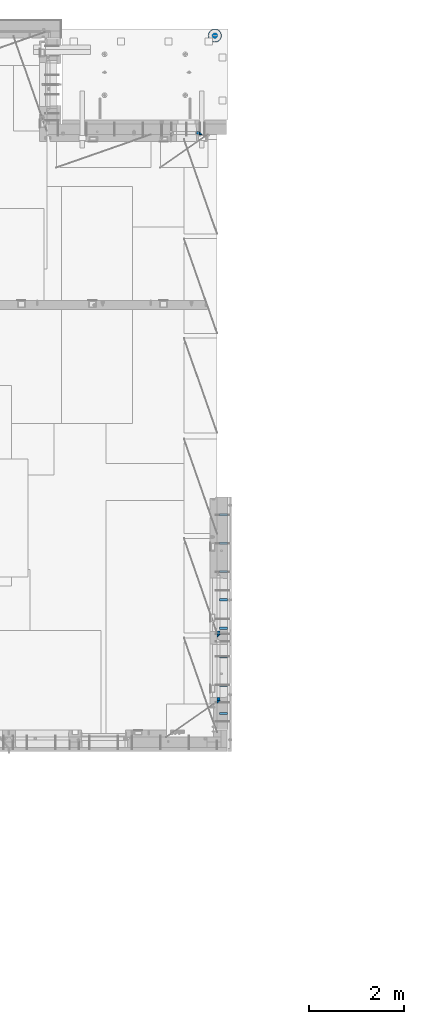
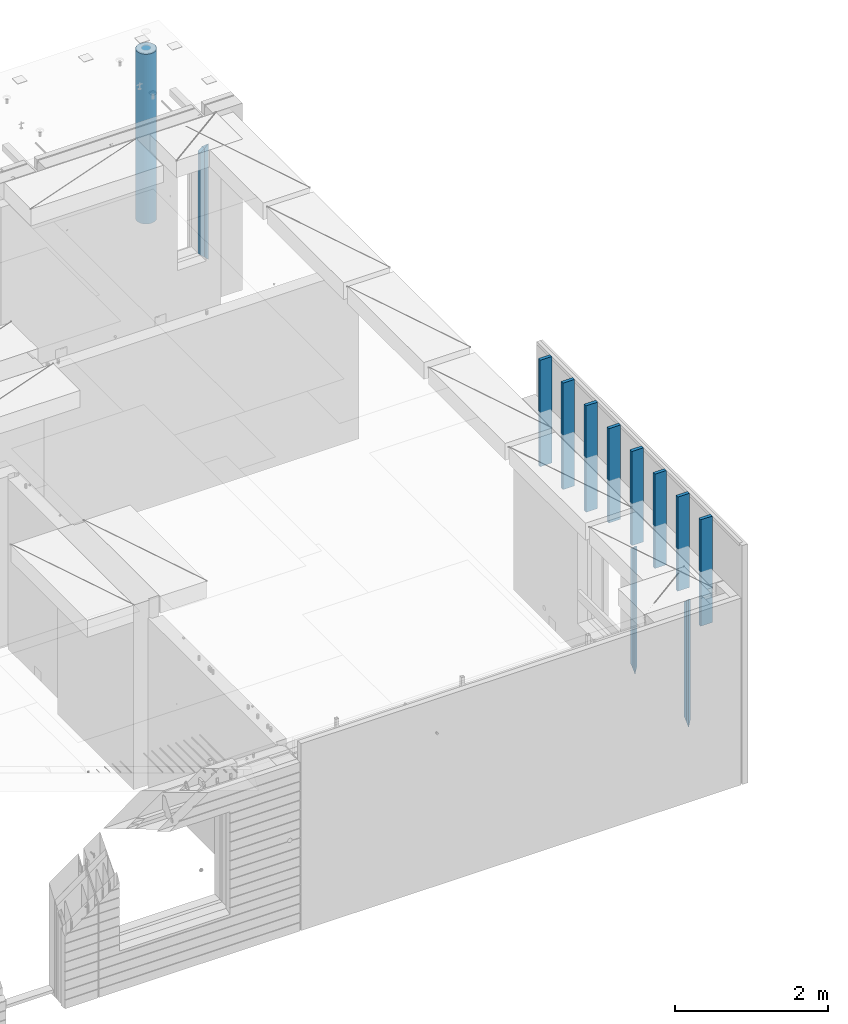
# One storey, part 6 of 309: 15 columns, 3 elements without a shape of their own.
"""IFC2X3 building model written with IfcOpenShell, lengths in millimetres."""

from ifc_helpers import new_model, si_unit, frame, origin_with_axes, place, context, subcontext, project, spatial, faceted_brep, material, type_object, element, aggregate, save


model = new_model("IFC2X3")

# Units and contexts
model_context = context("Model", 3, precision=1e-05, world=origin_with_axes())
body_context = subcontext(model_context, "Body", "Model", "MODEL_VIEW")
ifc_project = project(units=[si_unit("LENGTHUNIT", "METRE", prefix="MILLI"), si_unit("AREAUNIT", "SQUARE_METRE"), si_unit("VOLUMEUNIT", "CUBIC_METRE"), si_unit("MASSUNIT", "GRAM", prefix="KILO"), si_unit("TIMEUNIT", "SECOND"), si_unit("PLANEANGLEUNIT", "RADIAN"), si_unit("SOLIDANGLEUNIT", "STERADIAN"), si_unit("THERMODYNAMICTEMPERATUREUNIT", "DEGREE_CELSIUS"), si_unit("LUMINOUSINTENSITYUNIT", "LUMEN")], contexts=[model_context])

# Site, building, storey
site_placement = place(None, origin_with_axes())
site = spatial("IfcSite", under=ifc_project, at=site_placement, CompositionType="ELEMENT")
building_placement = place(site_placement, origin_with_axes())
building = spatial("IfcBuilding", under=site, at=building_placement, CompositionType="ELEMENT")
storey_placement = place(building_placement, origin_with_axes())
storey = spatial("IfcBuildingStorey", under=building, at=storey_placement, Name="7", CompositionType="ELEMENT", Elevation=0.0)

# Assembly, columns
assembly_1_placement = place(storey_placement, origin_with_axes())
assembly_1 = element("IfcElementAssembly", 1, at=assembly_1_placement, inside=storey, AssemblyPlace="NOTDEFINED", PredefinedType="REINFORCEMENT_UNIT")
ifc_material_1 = material(Name="TIMBER/T24")
column_type_1 = type_object("IfcColumnType", Name="PK50X175", PredefinedType="NOTDEFINED")
column_1_placement = place(assembly_1_placement, frame((35192.5, 8350.00024414063, 101870.0), z_axis=(-1.0, 3.00000001838171e-08, 0.0), x_axis=(0.0, 0.0, 1.0)))
column_1 = element("IfcColumn", 2, at=column_1_placement, type_object=column_type_1, material=ifc_material_1, ObjectType="PK50X175", context=body_context, shape_type="Brep", body=[
    faceted_brep([(0.0, 25.0, 87.5), (0.0, -25.0, 87.5), (1700.0, -25.0, 87.5), (1700.0, 25.0, 87.5), (0.0, -25.0, -87.5), (1700.0, -25.0, -87.5), (0.0, 25.0, -87.5), (1700.0, 25.0, -87.5)], [[[0, 1, 2, 3]], [[1, 4, 5, 2]], [[4, 6, 7, 5]], [[6, 0, 3, 7]], [[5, 7, 3, 2]], [[6, 4, 1, 0]]]),
])
column_2_placement = place(assembly_1_placement, frame((35192.5, 8950.00024414063, 102065.0), z_axis=(-1.0, 3.00000001838171e-08, 0.0), x_axis=(0.0, 0.0, 1.0)))
column_2 = element("IfcColumn", 3, at=column_2_placement, type_object=column_type_1, material=ifc_material_1, ObjectType="PK50X175", context=body_context, shape_type="Brep", body=[
    faceted_brep([(0.0, 25.0, 87.5), (0.0, -25.0, 87.5), (1505.0, -25.0, 87.5), (1505.0, 25.0, 87.5), (0.0, -25.0, -87.5), (1505.0, -25.0, -87.5), (0.0, 25.0, -87.5), (1505.0, 25.0, -87.5)], [[[0, 1, 2, 3]], [[1, 4, 5, 2]], [[4, 6, 7, 5]], [[6, 0, 3, 7]], [[5, 7, 3, 2]], [[6, 4, 1, 0]]]),
])
column_3_placement = place(assembly_1_placement, frame((35192.5, 9550.00024414063, 102065.0), z_axis=(-1.0, 3.00000001838171e-08, 0.0), x_axis=(0.0, 0.0, 1.0)))
column_3 = element("IfcColumn", 4, at=column_3_placement, type_object=column_type_1, material=ifc_material_1, ObjectType="PK50X175", context=body_context, shape_type="Brep", body=[
    faceted_brep([(0.0, 25.0, 87.5), (0.0, -25.0, 87.5), (1505.0, -25.0, 87.5), (1505.0, 25.0, 87.5), (0.0, -25.0, -87.5), (1505.0, -25.0, -87.5), (0.0, 25.0, -87.5), (1505.0, 25.0, -87.5)], [[[0, 1, 2, 3]], [[1, 4, 5, 2]], [[4, 6, 7, 5]], [[6, 0, 3, 7]], [[5, 7, 3, 2]], [[6, 4, 1, 0]]]),
])
column_4_placement = place(assembly_1_placement, frame((35192.5, 10150.0002441406, 102065.0), z_axis=(-1.0, 3.00000001838171e-08, 0.0), x_axis=(0.0, 0.0, 1.0)))
column_4 = element("IfcColumn", 5, at=column_4_placement, type_object=column_type_1, material=ifc_material_1, ObjectType="PK50X175", context=body_context, shape_type="Brep", body=[
    faceted_brep([(0.0, 25.0, 87.5), (0.0, -25.0, 87.5), (1505.0, -25.0, 87.5), (1505.0, 25.0, 87.5), (0.0, -25.0, -87.5), (1505.0, -25.0, -87.5), (0.0, 25.0, -87.5), (1505.0, 25.0, -87.5)], [[[0, 1, 2, 3]], [[1, 4, 5, 2]], [[4, 6, 7, 5]], [[6, 0, 3, 7]], [[5, 7, 3, 2]], [[6, 4, 1, 0]]]),
])
column_5_placement = place(assembly_1_placement, frame((35192.5, 10750.0002441406, 102065.0), z_axis=(-1.0, 3.00000001838171e-08, 0.0), x_axis=(0.0, 0.0, 1.0)))
column_5 = element("IfcColumn", 6, at=column_5_placement, type_object=column_type_1, material=ifc_material_1, ObjectType="PK50X175", context=body_context, shape_type="Brep", body=[
    faceted_brep([(0.0, 25.0, 87.5), (0.0, -25.0, 87.5), (1505.0, -25.0, 87.5), (1505.0, 25.0, 87.5), (0.0, -25.0, -87.5), (1505.0, -25.0, -87.5), (0.0, 25.0, -87.5), (1505.0, 25.0, -87.5)], [[[0, 1, 2, 3]], [[1, 4, 5, 2]], [[4, 6, 7, 5]], [[6, 0, 3, 7]], [[5, 7, 3, 2]], [[6, 4, 1, 0]]]),
])
column_6_placement = place(assembly_1_placement, frame((35192.5, 11350.0002441406, 101870.0), z_axis=(-1.0, 3.00000001838171e-08, 0.0), x_axis=(0.0, 0.0, 1.0)))
column_6 = element("IfcColumn", 7, at=column_6_placement, type_object=column_type_1, material=ifc_material_1, ObjectType="PK50X175", context=body_context, shape_type="Brep", body=[
    faceted_brep([(0.0, 25.0, 87.5), (0.0, -25.0, 87.5), (1700.0, -25.0, 87.5), (1700.0, 25.0, 87.5), (0.0, -25.0, -87.5), (1700.0, -25.0, -87.5), (0.0, 25.0, -87.5), (1700.0, 25.0, -87.5)], [[[0, 1, 2, 3]], [[1, 4, 5, 2]], [[4, 6, 7, 5]], [[6, 0, 3, 7]], [[5, 7, 3, 2]], [[6, 4, 1, 0]]]),
])
column_7_placement = place(assembly_1_placement, frame((35192.5, 11950.0002441406, 101870.0), z_axis=(-1.0, 3.00000001838171e-08, 0.0), x_axis=(0.0, 0.0, 1.0)))
column_7 = element("IfcColumn", 8, at=column_7_placement, type_object=column_type_1, material=ifc_material_1, ObjectType="PK50X175", context=body_context, shape_type="Brep", body=[
    faceted_brep([(0.0, 25.0, 87.5), (0.0, -25.0, 87.5), (1700.0, -25.0, 87.5), (1700.0, 25.0, 87.5), (0.0, -25.0, -87.5), (1700.0, -25.0, -87.5), (0.0, 25.0, -87.5), (1700.0, 25.0, -87.5)], [[[0, 1, 2, 3]], [[1, 4, 5, 2]], [[4, 6, 7, 5]], [[6, 0, 3, 7]], [[5, 7, 3, 2]], [[6, 4, 1, 0]]]),
])
column_8_placement = place(assembly_1_placement, frame((35192.5, 12550.0002441406, 101870.0), z_axis=(-1.0, 3.00000001838171e-08, 0.0), x_axis=(0.0, 0.0, 1.0)))
column_8 = element("IfcColumn", 9, at=column_8_placement, type_object=column_type_1, material=ifc_material_1, ObjectType="PK50X175", context=body_context, shape_type="Brep", body=[
    faceted_brep([(0.0, 25.0, 87.5), (0.0, -25.0, 87.5), (1700.0, -25.0, 87.5), (1700.0, 25.0, 87.5), (0.0, -25.0, -87.5), (1700.0, -25.0, -87.5), (0.0, 25.0, -87.5), (1700.0, 25.0, -87.5)], [[[0, 1, 2, 3]], [[1, 4, 5, 2]], [[4, 6, 7, 5]], [[6, 0, 3, 7]], [[5, 7, 3, 2]], [[6, 4, 1, 0]]]),
])

# Assembly, column
assembly_2_placement = place(storey_placement, origin_with_axes())
assembly_2 = element("IfcElementAssembly", 10, at=assembly_2_placement, inside=storey, AssemblyPlace="NOTDEFINED", PredefinedType="REINFORCEMENT_UNIT")
ifc_material_2 = material(Name="CONCRETE/C25/30")
column_type_2 = type_object("IfcColumnType", PredefinedType="NOTDEFINED")
column_9_placement = place(assembly_2_placement, frame((34714.9994055559, 20609.9951872276, 100420.0), z_axis=(-1.0, 3.00000001838171e-08, 0.0), x_axis=(0.0, 0.0, 1.0)))
column_9 = element("IfcColumn", 11, at=column_9_placement, type_object=column_type_2, material=ifc_material_2, Name="SK", context=body_context, shape_type="Brep", body=[
    faceted_brep([(1795.00000000001, -30.0, 30.0), (1855.0, -30.0, -30.0), (1795.00000000001, 30.0, 30.0), (0.0, -30.0, -30.0), (60.0000000000073, 30.0, 30.0), (60.0000000000073, -30.0, 30.0)], [[[0, 1, 2]], [[2, 1, 3, 4]], [[0, 2, 4, 5]], [[1, 0, 5, 3]], [[4, 3, 5]]]),
])

# Column
column_10_placement = place(assembly_1_placement, frame((35090.0, 8595.0001381367, 100120.0), z_axis=(0.0, 1.0, 0.0), x_axis=(0.0, 0.0, 1.0)))
column_10 = element("IfcColumn", 12, at=column_10_placement, type_object=column_type_2, material=ifc_material_2, Name="SK", context=body_context, shape_type="Brep", body=[
    faceted_brep([(1995.0, -30.0, 30.0), (2055.0, -30.0, -30.0), (1995.0, 30.0, 30.0), (60.0000000000073, 30.0, 30.0), (60.0000000000073, -30.0, 30.0), (0.0, -30.0, -30.0)], [[[0, 1, 2]], [[0, 2, 3, 4]], [[1, 0, 4, 5]], [[2, 1, 5, 3]], [[3, 5, 4]]]),
])

column_11_placement = place(assembly_1_placement, frame((35090.0, 9995.00023350414, 100120.0), z_axis=(0.0, 1.0, 0.0), x_axis=(0.0, 0.0, 1.0)))
column_11 = element("IfcColumn", 13, at=column_11_placement, type_object=column_type_2, material=ifc_material_2, Name="SK", context=body_context, shape_type="Brep", body=[
    faceted_brep([(1995.0, -30.0, 30.0), (2055.0, -30.0, -30.0), (1995.0, 30.0, 30.0), (60.0000000000073, 30.0, 30.0), (60.0000000000073, -30.0, 30.0), (0.0, -30.0, -30.0)], [[[0, 1, 2]], [[0, 2, 3, 4]], [[1, 0, 4, 5]], [[2, 1, 5, 3]], [[3, 5, 4]]]),
])

column_type_3 = type_object("IfcColumnType", PredefinedType="NOTDEFINED")
column_12_placement = place(assembly_2_placement, frame((34649.9994055559, 20609.9951872276, 100480.0), z_axis=(-1.0, 3.00000001838171e-08, 0.0), x_axis=(0.0, 0.0, 1.0)))
column_12 = element("IfcColumn", 14, at=column_12_placement, type_object=column_type_3, material=ifc_material_2, Name="SK", context=body_context, shape_type="Brep", body=[
    faceted_brep([(1680.09318526485, -30.0, 29.057950538423), (1735.0, -30.0, -35.0), (1735.0, 30.0, -35.0), (1678.70322387519, 30.0, 30.6795721600429), (0.0, 30.0, -35.0), (56.2967761248292, 30.0, 30.6795721600429), (54.90681473515, -30.0, 29.057950538423), (0.0, -30.0, -35.0)], [[[0, 1, 2, 3]], [[3, 2, 4, 5]], [[0, 3, 5, 6]], [[1, 0, 6, 7]], [[2, 1, 7, 4]], [[6, 5, 4, 7]]]),
])

aggregate(assembly_2, [column_9, column_12])

column_13_placement = place(assembly_1_placement, frame((35090.0, 8660.0001381367, 100180.0), z_axis=(0.0, 1.0, 0.0), x_axis=(0.0, 0.0, 1.0)))
column_13 = element("IfcColumn", 15, at=column_13_placement, type_object=column_type_3, material=ifc_material_2, Name="SK", context=body_context, shape_type="Brep", body=[
    faceted_brep([(1935.0, -30.0, -35.0), (1935.0, 30.0, -35.0), (1878.70664546244, 30.0, 30.6755803082433), (1880.09660685209, -30.0, 29.0539586866216), (56.2933545375854, 30.0, 30.6755803082433), (54.9033931479207, -30.0, 29.0539586866216), (0.0, -30.0, -35.0), (0.0, 30.0, -35.0)], [[[0, 1, 2, 3]], [[3, 2, 4, 5]], [[0, 3, 5, 6]], [[1, 0, 6, 7]], [[2, 1, 7, 4]], [[6, 5, 4, 7]]]),
])

column_14_placement = place(assembly_1_placement, frame((35090.0, 10060.0002335041, 100180.0), z_axis=(0.0, 1.0, 0.0), x_axis=(0.0, 0.0, 1.0)))
column_14 = element("IfcColumn", 16, at=column_14_placement, type_object=column_type_3, material=ifc_material_2, Name="SK", context=body_context, shape_type="Brep", body=[
    faceted_brep([(1935.0, -30.0, -35.0), (1935.0, 30.0, -35.0), (1878.70705418001, 30.0, 30.6751034710851), (1880.09701556964, -30.0, 29.0534818494634), (56.2929458200088, 30.0, 30.6751034710851), (54.9029844303586, -30.0, 29.0534818494634), (0.0, -30.0, -35.0), (0.0, 30.0, -35.0)], [[[0, 1, 2, 3]], [[3, 2, 4, 5]], [[0, 3, 5, 6]], [[1, 0, 6, 7]], [[2, 1, 7, 4]], [[6, 5, 4, 7]]]),
])

aggregate(assembly_1, [column_1, column_2, column_3, column_4, column_5, column_6, column_7, column_8, column_13, column_10, column_14, column_11])

# Assembly, column
assembly_3_placement = place(storey_placement, origin_with_axes())
assembly_3 = element("IfcElementAssembly", 17, at=assembly_3_placement, inside=storey, AssemblyPlace="NOTDEFINED", PredefinedType="REINFORCEMENT_UNIT")
ifc_material_3 = material(Name="CONCRETE/C30/37")
column_type_4 = type_object("IfcColumnType", Name="D280", PredefinedType="NOTDEFINED")
column_15_placement = place(assembly_3_placement, frame((35009.9987952044, 22669.984888838, 99725.0), z_axis=(-1.0, 3.00000001838171e-08, 0.0), x_axis=(0.0, 0.0, 1.0)))
column_15 = element("IfcColumn", 18, at=column_15_placement, type_object=column_type_4, material=ifc_material_3, ObjectType="D280", context=body_context, shape_type="Brep", body=[
    faceted_brep([(0.0, -140.0, 0.0), (0.0, -136.489907705454, -31.1529307538876), (2710.0, -136.489907705454, -31.1529307538876), (2710.0, -140.0, 0.0), (0.0, -126.135641506338, -60.7437234764584), (2710.0, -126.135641506338, -60.7437234764584), (0.0, -109.456407545524, -87.2885722602223), (2710.0, -109.456407545524, -87.2885722602223), (0.0, -87.2885722602223, -109.456407545527), (2710.0, -87.2885722602223, -109.456407545527), (0.0, -60.7437234764584, -126.135641506342), (2710.0, -60.7437234764584, -126.135641506342), (0.0, -31.152930753884, -136.489907705458), (2710.0, -31.152930753884, -136.489907705458), (0.0, 0.0, -140.0), (2710.0, 0.0, -140.0), (0.0, 31.152930753884, -136.489907705458), (2710.0, 31.152930753884, -136.489907705458), (0.0, 60.7437234764584, -126.135641506342), (2710.0, 60.7437234764584, -126.135641506342), (0.0, 87.2885722602223, -109.456407545527), (2710.0, 87.2885722602223, -109.456407545527), (0.0, 109.456407545524, -87.2885722602223), (2710.0, 109.456407545524, -87.2885722602223), (0.0, 126.135641506338, -60.7437234764584), (2710.0, 126.135641506338, -60.7437234764584), (0.0, 136.489907705454, -31.1529307538876), (2710.0, 136.489907705454, -31.1529307538876), (0.0, 140.0, 0.0), (2710.0, 140.0, 0.0), (0.0, 136.489907705454, 31.1529307538876), (2710.0, 136.489907705454, 31.1529307538876), (0.0, 126.135641506338, 60.7437234764584), (2710.0, 126.135641506338, 60.7437234764584), (0.0, 109.456407545524, 87.2885722602223), (2710.0, 109.456407545524, 87.2885722602223), (0.0, 87.2885722602223, 109.456407545527), (2710.0, 87.2885722602223, 109.456407545527), (0.0, 60.7437234764584, 126.135641506342), (2710.0, 60.7437234764584, 126.135641506342), (0.0, 31.152930753884, 136.489907705458), (2710.0, 31.152930753884, 136.489907705458), (0.0, 0.0, 140.0), (2710.0, 0.0, 140.0), (0.0, -31.152930753884, 136.489907705458), (2710.0, -31.152930753884, 136.489907705458), (0.0, -60.7437234764584, 126.135641506342), (2710.0, -60.7437234764584, 126.135641506342), (0.0, -87.2885722602223, 109.456407545527), (2710.0, -87.2885722602223, 109.456407545527), (0.0, -109.456407545524, 87.2885722602223), (2710.0, -109.456407545524, 87.2885722602223), (0.0, -126.135641506338, 60.7437234764584), (2710.0, -126.135641506338, 60.7437234764584), (0.0, -136.489907705454, 31.1529307538876), (2710.0, -136.489907705454, 31.1529307538876)], [[[0, 1, 2, 3]], [[1, 4, 5, 2]], [[4, 6, 7, 5]], [[6, 8, 9, 7]], [[8, 10, 11, 9]], [[10, 12, 13, 11]], [[12, 14, 15, 13]], [[14, 16, 17, 15]], [[16, 18, 19, 17]], [[18, 20, 21, 19]], [[20, 22, 23, 21]], [[22, 24, 25, 23]], [[24, 26, 27, 25]], [[26, 28, 29, 27]], [[28, 30, 31, 29]], [[30, 32, 33, 31]], [[32, 34, 35, 33]], [[34, 36, 37, 35]], [[36, 38, 39, 37]], [[38, 40, 41, 39]], [[40, 42, 43, 41]], [[42, 44, 45, 43]], [[44, 46, 47, 45]], [[46, 48, 49, 47]], [[48, 50, 51, 49]], [[50, 52, 53, 51]], [[52, 54, 55, 53]], [[54, 0, 3, 55]], [[5, 7, 9, 11, 13, 15, 17, 19, 21, 23, 25, 27, 29, 31, 33, 35, 37, 39, 41, 43, 45, 47, 49, 51, 53, 55, 3, 2]], [[54, 52, 50, 48, 46, 44, 42, 40, 38, 36, 34, 32, 30, 28, 26, 24, 22, 20, 18, 16, 14, 12, 10, 8, 6, 4, 1, 0]]]),
])
aggregate(assembly_3, [column_15])

save(model, "model.ifc")
